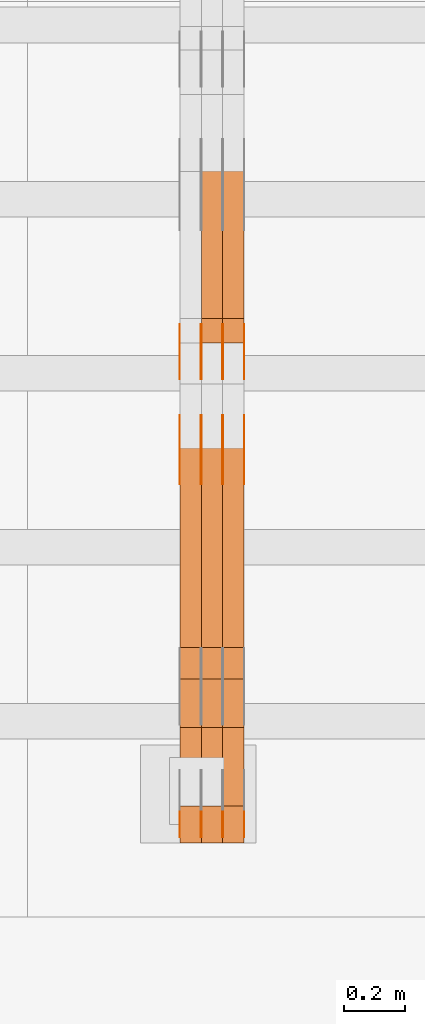
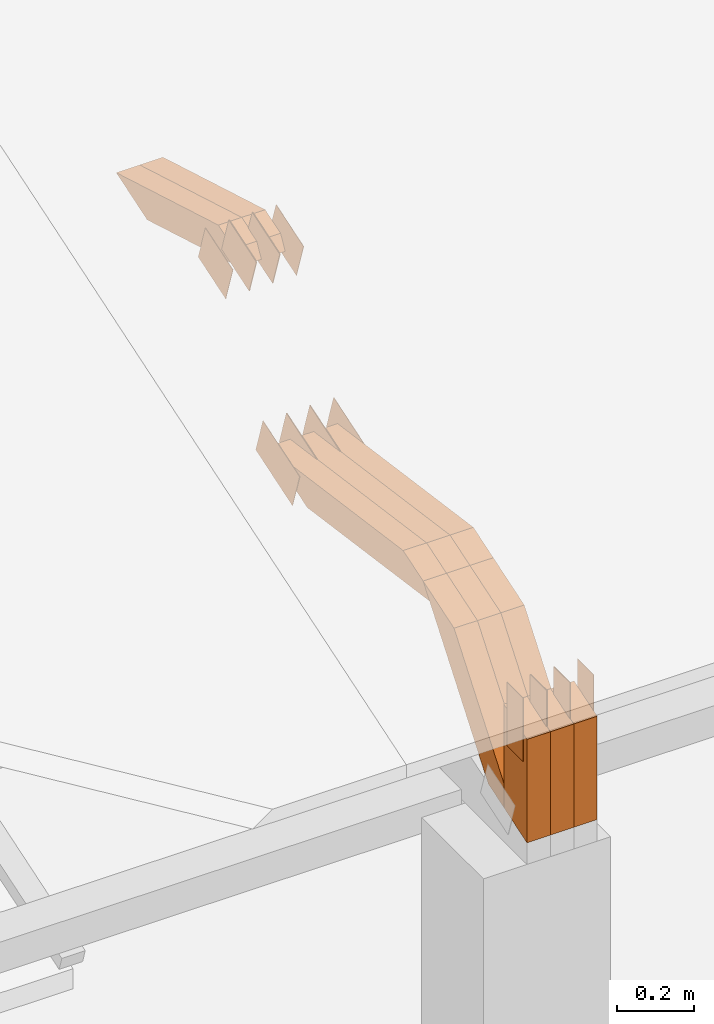
# One storey, part 54 of 385: 29 proxies.
"""IFC2X3 building model written with IfcOpenShell, lengths in millimetres."""

from ifc_helpers import new_model, entity, si_unit, converted_unit, derived_unit, direction, frame, frame_2d, origin, place, context, subcontext, project, spatial, polyline, rectangle, outline, extrude, source, transform, mapped, material, type_object, type_shapes, element, save


model = new_model("IFC2X3")

# Units and contexts
model_context = context("Model", 3, precision=0.01, world=origin(), true_north=direction((6.12303176911189e-17, 1.0)))
body_context = subcontext(model_context, "Body", "Model", "MODEL_VIEW")
ifc_project = project(units=[si_unit("LENGTHUNIT", "METRE", prefix="MILLI"), si_unit("AREAUNIT", "SQUARE_METRE"), si_unit("VOLUMEUNIT", "CUBIC_METRE"), converted_unit("PLANEANGLEUNIT", "DEGREE", entity("IfcRatioMeasure", 0.0174532925199433), si_unit("PLANEANGLEUNIT", "RADIAN"), dimensions=[0, 0, 0, 0, 0, 0, 0]), si_unit("MASSUNIT", "GRAM", prefix="KILO"), derived_unit("MASSDENSITYUNIT", [(si_unit("MASSUNIT", "GRAM", prefix="KILO"), 1), (si_unit("LENGTHUNIT", "METRE"), -3)]), si_unit("TIMEUNIT", "SECOND"), si_unit("FREQUENCYUNIT", "HERTZ"), si_unit("THERMODYNAMICTEMPERATUREUNIT", "DEGREE_CELSIUS"), derived_unit("THERMALTRANSMITTANCEUNIT", [(si_unit("MASSUNIT", "GRAM", prefix="KILO"), 1), (si_unit("THERMODYNAMICTEMPERATUREUNIT", "KELVIN"), -1), (si_unit("TIMEUNIT", "SECOND"), -3)]), derived_unit("VOLUMETRICFLOWRATEUNIT", [(si_unit("LENGTHUNIT", "METRE"), 3), (si_unit("TIMEUNIT", "SECOND"), -1)]), si_unit("ELECTRICCURRENTUNIT", "AMPERE"), si_unit("ELECTRICVOLTAGEUNIT", "VOLT"), si_unit("POWERUNIT", "WATT"), si_unit("FORCEUNIT", "NEWTON", prefix="KILO"), si_unit("ILLUMINANCEUNIT", "LUX"), si_unit("LUMINOUSFLUXUNIT", "LUMEN"), si_unit("LUMINOUSINTENSITYUNIT", "CANDELA"), derived_unit("USERDEFINED", [(si_unit("MASSUNIT", "GRAM", prefix="KILO"), -1), (si_unit("LENGTHUNIT", "METRE"), -2), (si_unit("TIMEUNIT", "SECOND"), 3), (si_unit("LUMINOUSFLUXUNIT", "LUMEN"), 1)]), derived_unit("LINEARVELOCITYUNIT", [(si_unit("LENGTHUNIT", "METRE"), 1), (si_unit("TIMEUNIT", "SECOND"), -1)]), si_unit("PRESSUREUNIT", "PASCAL"), derived_unit("USERDEFINED", [(si_unit("LENGTHUNIT", "METRE"), -2), (si_unit("MASSUNIT", "GRAM", prefix="KILO"), 1), (si_unit("TIMEUNIT", "SECOND"), -2)])], contexts=[model_context])

# Site, building, storey
site_placement = place(None, origin())
site = spatial("IfcSite", under=ifc_project, at=site_placement, CompositionType="ELEMENT")
building_placement = place(site_placement, origin())
building = spatial("IfcBuilding", under=site, at=building_placement, CompositionType="ELEMENT")
storey_placement = place(building_placement, origin())
storey = spatial("IfcBuildingStorey", under=building, at=storey_placement, Name="Default", CompositionType="ELEMENT", Elevation=0.0)

# Proxies
ifc_material_1 = material(Name="IfcSurfaceStyle #133094")
building_element_proxy_type_1 = type_object("IfcBuildingElementProxyType", PredefinedType="NOTDEFINED", material=ifc_material_1)
shared_shape_1 = source(origin(), body_context, "Body", "SweptSolid", [
    extrude(outline(polyline([(-99.9998204243802, -60.000067376167), (99.9998338462265, -60.000067376167), (99.9998204243802, 60.000067376167), (-99.9998338462265, 60.000067376167), (-99.9998204243802, -60.000067376167)])), frame((100.000602015329, 60.0001864986889, 0.0), z_axis=(0.0, 0.0, 1.0), x_axis=(-1.0, 0.0, 0.0)), (0.0, 0.0, 1.0), 1.3),
])
type_shapes(building_element_proxy_type_1, [shared_shape_1])
proxy_1_placement = place(building_placement, frame((9386.29999999998, 4114.85465165112, 513.097031388771), z_axis=(-1.0, 0.0, 0.0), x_axis=(0.0, 0.951056516295124, 0.309016994375039)))
element("IfcBuildingElementProxy", 1, at=proxy_1_placement, inside=storey, type_object=building_element_proxy_type_1, material=ifc_material_1, context=body_context, shape_type="MappedRepresentation", body=[
    mapped(shared_shape_1, transform((0.0, 0.0, 0.0), scale=1.0)),
])
ifc_material_2 = material(Name="IfcSurfaceStyle #133037")
building_element_proxy_type_2 = type_object("IfcBuildingElementProxyType", PredefinedType="NOTDEFINED", material=ifc_material_2)
shared_shape_2 = source(origin(), body_context, "Body", "SweptSolid", [
    extrude(outline(polyline([(-99.9998204243802, -60.000067376167), (99.9998338462265, -60.000067376167), (99.9998204243802, 60.000067376167), (-99.9998338462265, 60.000067376167), (-99.9998204243802, -60.000067376167)])), frame((100.000602015329, 60.0001864986889, 0.0), z_axis=(0.0, 0.0, 1.0), x_axis=(-1.0, 0.0, 0.0)), (0.0, 0.0, 1.0), 1.3),
])
type_shapes(building_element_proxy_type_2, [shared_shape_2])
proxy_2_placement = place(building_placement, frame((9315.0, 4114.85465165112, 513.097031388771), z_axis=(-1.0, 0.0, 0.0), x_axis=(0.0, 0.951056516295124, 0.309016994375039)))
element("IfcBuildingElementProxy", 2, at=proxy_2_placement, inside=storey, type_object=building_element_proxy_type_2, material=ifc_material_2, context=body_context, shape_type="MappedRepresentation", body=[
    mapped(shared_shape_2, transform((0.0, 0.0, 0.0), scale=1.0)),
])
ifc_material_3 = material(Name="IfcSurfaceStyle #132980")
building_element_proxy_type_3 = type_object("IfcBuildingElementProxyType", PredefinedType="NOTDEFINED", material=ifc_material_3)
shared_shape_3 = source(origin(), body_context, "Body", "SweptSolid", [
    extrude(outline(polyline([(-99.9998204243802, -60.000067376167), (99.9998338462265, -60.000067376167), (99.9998204243802, 60.000067376167), (-99.9998338462265, 60.000067376167), (-99.9998204243802, -60.000067376167)])), frame((100.000602015329, 60.0001864986889, 0.0), z_axis=(0.0, 0.0, 1.0), x_axis=(-1.0, 0.0, 0.0)), (0.0, 0.0, 1.0), 1.3),
])
type_shapes(building_element_proxy_type_3, [shared_shape_3])
proxy_3_placement = place(building_placement, frame((9316.29999999998, 4114.85465165112, 513.097031388771), z_axis=(-1.0, 0.0, 0.0), x_axis=(0.0, 0.951056516295124, 0.309016994375039)))
element("IfcBuildingElementProxy", 3, at=proxy_3_placement, inside=storey, type_object=building_element_proxy_type_3, material=ifc_material_3, context=body_context, shape_type="MappedRepresentation", body=[
    mapped(shared_shape_3, transform((0.0, 0.0, 0.0), scale=1.0)),
])
ifc_material_4 = material(Name="IfcSurfaceStyle #132923")
building_element_proxy_type_4 = type_object("IfcBuildingElementProxyType", PredefinedType="NOTDEFINED", material=ifc_material_4)
shared_shape_4 = source(origin(), body_context, "Body", "SweptSolid", [
    extrude(outline(polyline([(-99.9998204243802, -60.000067376167), (99.9998338462265, -60.000067376167), (99.9998204243802, 60.000067376167), (-99.9998338462265, 60.000067376167), (-99.9998204243802, -60.000067376167)])), frame((100.000602015329, 60.0001864986889, 0.0), z_axis=(0.0, 0.0, 1.0), x_axis=(-1.0, 0.0, 0.0)), (0.0, 0.0, 1.0), 1.29999999999998),
])
type_shapes(building_element_proxy_type_4, [shared_shape_4])
proxy_4_placement = place(building_placement, frame((9245.0, 4114.85465165112, 513.097031388771), z_axis=(-1.0, 0.0, 0.0), x_axis=(0.0, 0.951056516295124, 0.309016994375039)))
element("IfcBuildingElementProxy", 4, at=proxy_4_placement, inside=storey, type_object=building_element_proxy_type_4, material=ifc_material_4, context=body_context, shape_type="MappedRepresentation", body=[
    mapped(shared_shape_4, transform((0.0, 0.0, 0.0), scale=1.0)),
])
ifc_material_5 = material(Name="IfcSurfaceStyle #132866")
building_element_proxy_type_5 = type_object("IfcBuildingElementProxyType", PredefinedType="NOTDEFINED", material=ifc_material_5)
shared_shape_5 = source(origin(), body_context, "Body", "SweptSolid", [
    extrude(outline(polyline([(-99.9998204243802, -60.000067376167), (99.9998338462265, -60.000067376167), (99.9998204243802, 60.000067376167), (-99.9998338462265, 60.000067376167), (-99.9998204243802, -60.000067376167)])), frame((100.000602015329, 60.0001864986889, 0.0), z_axis=(0.0, 0.0, 1.0), x_axis=(-1.0, 0.0, 0.0)), (0.0, 0.0, 1.0), 1.29999999999998),
])
type_shapes(building_element_proxy_type_5, [shared_shape_5])
proxy_5_placement = place(building_placement, frame((9246.29999999998, 4114.85465165112, 513.097031388771), z_axis=(-1.0, 0.0, 0.0), x_axis=(0.0, 0.951056516295124, 0.309016994375039)))
element("IfcBuildingElementProxy", 5, at=proxy_5_placement, inside=storey, type_object=building_element_proxy_type_5, material=ifc_material_5, context=body_context, shape_type="MappedRepresentation", body=[
    mapped(shared_shape_5, transform((0.0, 0.0, 0.0), scale=1.0)),
])
ifc_material_6 = material(Name="IfcSurfaceStyle #132809")
building_element_proxy_type_6 = type_object("IfcBuildingElementProxyType", PredefinedType="NOTDEFINED", material=ifc_material_6)
shared_shape_6 = source(origin(), body_context, "Body", "SweptSolid", [
    extrude(outline(polyline([(-99.9998204243802, -60.000067376167), (99.9998338462265, -60.000067376167), (99.9998204243802, 60.000067376167), (-99.9998338462265, 60.000067376167), (-99.9998204243802, -60.000067376167)])), frame((100.000602015329, 60.0001864986889, 0.0), z_axis=(0.0, 0.0, 1.0), x_axis=(-1.0, 0.0, 0.0)), (0.0, 0.0, 1.0), 1.29999999999999),
])
type_shapes(building_element_proxy_type_6, [shared_shape_6])
proxy_6_placement = place(building_placement, frame((9175.0, 4114.85465165112, 513.097031388771), z_axis=(-1.0, 0.0, 0.0), x_axis=(0.0, 0.951056516295124, 0.309016994375039)))
element("IfcBuildingElementProxy", 6, at=proxy_6_placement, inside=storey, type_object=building_element_proxy_type_6, material=ifc_material_6, context=body_context, shape_type="MappedRepresentation", body=[
    mapped(shared_shape_6, transform((0.0, 0.0, 0.0), scale=1.0)),
])
ifc_material_7 = material(Name="IfcSurfaceStyle #125912")
building_element_proxy_type_7 = type_object("IfcBuildingElementProxyType", PredefinedType="NOTDEFINED", material=ifc_material_7)
shared_shape_7 = source(origin(), body_context, "Body", "SweptSolid", [
    extrude(outline(polyline([(-74.999865998172, -60.0000306612919), (74.999869989555, -60.0000306612919), (74.999865998172, 60.0000306612919), (-74.999869989555, 60.0000306612919), (-74.999865998172, -60.0000306612919)])), frame((75.0006726017528, 60.0001996460842, 0.0), z_axis=(0.0, 0.0, 1.0), x_axis=(-1.0, 0.0, 0.0)), (0.0, 0.0, 1.0), 1.3),
])
type_shapes(building_element_proxy_type_7, [shared_shape_7])
proxy_7_placement = place(building_placement, frame((9386.29999999998, 4460.38978242656, 957.314497110567), z_axis=(-1.0, 0.0, 0.0), x_axis=(0.0, 0.951056516295154, 0.309016994374948)))
element("IfcBuildingElementProxy", 7, at=proxy_7_placement, inside=storey, type_object=building_element_proxy_type_7, material=ifc_material_7, context=body_context, shape_type="MappedRepresentation", body=[
    mapped(shared_shape_7, transform((0.0, 0.0, 0.0), scale=1.0)),
])
ifc_material_8 = material(Name="IfcSurfaceStyle #125855")
building_element_proxy_type_8 = type_object("IfcBuildingElementProxyType", PredefinedType="NOTDEFINED", material=ifc_material_8)
shared_shape_8 = source(origin(), body_context, "Body", "SweptSolid", [
    extrude(outline(polyline([(-74.999865998172, -60.0000306612919), (74.999869989555, -60.0000306612919), (74.999865998172, 60.0000306612919), (-74.999869989555, 60.0000306612919), (-74.999865998172, -60.0000306612919)])), frame((75.0006726017528, 60.0001996460842, 0.0), z_axis=(0.0, 0.0, 1.0), x_axis=(-1.0, 0.0, 0.0)), (0.0, 0.0, 1.0), 1.3),
])
type_shapes(building_element_proxy_type_8, [shared_shape_8])
proxy_8_placement = place(building_placement, frame((9315.0, 4460.38978242656, 957.314497110567), z_axis=(-1.0, 0.0, 0.0), x_axis=(0.0, 0.951056516295154, 0.309016994374948)))
element("IfcBuildingElementProxy", 8, at=proxy_8_placement, inside=storey, type_object=building_element_proxy_type_8, material=ifc_material_8, context=body_context, shape_type="MappedRepresentation", body=[
    mapped(shared_shape_8, transform((0.0, 0.0, 0.0), scale=1.0)),
])
ifc_material_9 = material(Name="IfcSurfaceStyle #125798")
building_element_proxy_type_9 = type_object("IfcBuildingElementProxyType", PredefinedType="NOTDEFINED", material=ifc_material_9)
shared_shape_9 = source(origin(), body_context, "Body", "SweptSolid", [
    extrude(outline(polyline([(-74.999865998172, -60.0000306612919), (74.999869989555, -60.0000306612919), (74.999865998172, 60.0000306612919), (-74.999869989555, 60.0000306612919), (-74.999865998172, -60.0000306612919)])), frame((75.0006726017528, 60.0001996460842, 0.0), z_axis=(0.0, 0.0, 1.0), x_axis=(-1.0, 0.0, 0.0)), (0.0, 0.0, 1.0), 1.3),
])
type_shapes(building_element_proxy_type_9, [shared_shape_9])
proxy_9_placement = place(building_placement, frame((9316.29999999998, 4460.38978242656, 957.314497110567), z_axis=(-1.0, 0.0, 0.0), x_axis=(0.0, 0.951056516295154, 0.309016994374948)))
element("IfcBuildingElementProxy", 9, at=proxy_9_placement, inside=storey, type_object=building_element_proxy_type_9, material=ifc_material_9, context=body_context, shape_type="MappedRepresentation", body=[
    mapped(shared_shape_9, transform((0.0, 0.0, 0.0), scale=1.0)),
])
ifc_material_10 = material(Name="IfcSurfaceStyle #125741")
building_element_proxy_type_10 = type_object("IfcBuildingElementProxyType", PredefinedType="NOTDEFINED", material=ifc_material_10)
shared_shape_10 = source(origin(), body_context, "Body", "SweptSolid", [
    extrude(outline(polyline([(-74.999865998172, -60.0000306612919), (74.999869989555, -60.0000306612919), (74.999865998172, 60.0000306612919), (-74.999869989555, 60.0000306612919), (-74.999865998172, -60.0000306612919)])), frame((75.0006726017528, 60.0001996460842, 0.0), z_axis=(0.0, 0.0, 1.0), x_axis=(-1.0, 0.0, 0.0)), (0.0, 0.0, 1.0), 1.29999999999999),
])
type_shapes(building_element_proxy_type_10, [shared_shape_10])
proxy_10_placement = place(building_placement, frame((9245.0, 4460.38978242656, 957.314497110567), z_axis=(-1.0, 0.0, 0.0), x_axis=(0.0, 0.951056516295154, 0.309016994374948)))
element("IfcBuildingElementProxy", 10, at=proxy_10_placement, inside=storey, type_object=building_element_proxy_type_10, material=ifc_material_10, context=body_context, shape_type="MappedRepresentation", body=[
    mapped(shared_shape_10, transform((0.0, 0.0, 0.0), scale=1.0)),
])
ifc_material_11 = material(Name="IfcSurfaceStyle #125684")
building_element_proxy_type_11 = type_object("IfcBuildingElementProxyType", PredefinedType="NOTDEFINED", material=ifc_material_11)
shared_shape_11 = source(origin(), body_context, "Body", "SweptSolid", [
    extrude(outline(polyline([(-74.999865998172, -60.0000306612919), (74.999869989555, -60.0000306612919), (74.999865998172, 60.0000306612919), (-74.999869989555, 60.0000306612919), (-74.999865998172, -60.0000306612919)])), frame((75.0006726017528, 60.0001996460842, 0.0), z_axis=(0.0, 0.0, 1.0), x_axis=(-1.0, 0.0, 0.0)), (0.0, 0.0, 1.0), 1.29999999999999),
])
type_shapes(building_element_proxy_type_11, [shared_shape_11])
proxy_11_placement = place(building_placement, frame((9246.29999999998, 4460.38978242656, 957.314497110567), z_axis=(-1.0, 0.0, 0.0), x_axis=(0.0, 0.951056516295154, 0.309016994374948)))
element("IfcBuildingElementProxy", 11, at=proxy_11_placement, inside=storey, type_object=building_element_proxy_type_11, material=ifc_material_11, context=body_context, shape_type="MappedRepresentation", body=[
    mapped(shared_shape_11, transform((0.0, 0.0, 0.0), scale=1.0)),
])
ifc_material_12 = material(Name="IfcSurfaceStyle #125627")
building_element_proxy_type_12 = type_object("IfcBuildingElementProxyType", PredefinedType="NOTDEFINED", material=ifc_material_12)
shared_shape_12 = source(origin(), body_context, "Body", "SweptSolid", [
    extrude(outline(polyline([(-74.999865998172, -60.0000306612919), (74.999869989555, -60.0000306612919), (74.999865998172, 60.0000306612919), (-74.999869989555, 60.0000306612919), (-74.999865998172, -60.0000306612919)])), frame((75.0006726017528, 60.0001996460842, 0.0), z_axis=(0.0, 0.0, 1.0), x_axis=(-1.0, 0.0, 0.0)), (0.0, 0.0, 1.0), 1.29999999999999),
])
type_shapes(building_element_proxy_type_12, [shared_shape_12])
proxy_12_placement = place(building_placement, frame((9175.0, 4460.38978242656, 957.314497110567), z_axis=(-1.0, 0.0, 0.0), x_axis=(0.0, 0.951056516295154, 0.309016994374948)))
element("IfcBuildingElementProxy", 12, at=proxy_12_placement, inside=storey, type_object=building_element_proxy_type_12, material=ifc_material_12, context=body_context, shape_type="MappedRepresentation", body=[
    mapped(shared_shape_12, transform((0.0, 0.0, 0.0), scale=1.0)),
])
ifc_material_13 = material(Name="IfcSurfaceStyle #123860")
building_element_proxy_type_13 = type_object("IfcBuildingElementProxyType", PredefinedType="NOTDEFINED", material=ifc_material_13)
shared_shape_13 = source(origin(), body_context, "Body", "SweptSolid", [
    extrude(rectangle(XDim=199.999969482422, YDim=84.0, at=frame_2d((1.4210854715202e-14, 0.0), x_axis=(1.0, 0.0))), frame((100.000010815955, 42.0, 0.0), z_axis=(0.0, 0.0, 1.0), x_axis=(-1.0, 0.0, 0.0)), (0.0, 0.0, 1.0), 1.3),
])
type_shapes(building_element_proxy_type_13, [shared_shape_13])
proxy_13_placement = place(building_placement, frame((9386.29999999998, 3042.0, 514.460048047401), z_axis=(-1.0, 0.0, 0.0), x_axis=(0.0, 0.0, -1.0)))
element("IfcBuildingElementProxy", 13, at=proxy_13_placement, inside=storey, type_object=building_element_proxy_type_13, material=ifc_material_13, context=body_context, shape_type="MappedRepresentation", body=[
    mapped(shared_shape_13, transform((0.0, 0.0, 0.0), scale=1.0)),
])
ifc_material_14 = material(Name="IfcSurfaceStyle #123803")
building_element_proxy_type_14 = type_object("IfcBuildingElementProxyType", PredefinedType="NOTDEFINED", material=ifc_material_14)
shared_shape_14 = source(origin(), body_context, "Body", "SweptSolid", [
    extrude(rectangle(XDim=199.999969482422, YDim=84.0, at=frame_2d((1.4210854715202e-14, 0.0), x_axis=(1.0, 0.0))), frame((100.000010815955, 42.0, 0.0), z_axis=(0.0, 0.0, 1.0), x_axis=(-1.0, 0.0, 0.0)), (0.0, 0.0, 1.0), 1.3),
])
type_shapes(building_element_proxy_type_14, [shared_shape_14])
proxy_14_placement = place(building_placement, frame((9315.0, 3042.0, 514.460048047401), z_axis=(-1.0, 0.0, 0.0), x_axis=(0.0, 0.0, -1.0)))
element("IfcBuildingElementProxy", 14, at=proxy_14_placement, inside=storey, type_object=building_element_proxy_type_14, material=ifc_material_14, context=body_context, shape_type="MappedRepresentation", body=[
    mapped(shared_shape_14, transform((0.0, 0.0, 0.0), scale=1.0)),
])
ifc_material_15 = material(Name="IfcSurfaceStyle #123746")
building_element_proxy_type_15 = type_object("IfcBuildingElementProxyType", PredefinedType="NOTDEFINED", material=ifc_material_15)
shared_shape_15 = source(origin(), body_context, "Body", "SweptSolid", [
    extrude(rectangle(XDim=199.999969482422, YDim=84.0, at=frame_2d((1.4210854715202e-14, 0.0), x_axis=(1.0, 0.0))), frame((100.000010815955, 42.0, 0.0), z_axis=(0.0, 0.0, 1.0), x_axis=(-1.0, 0.0, 0.0)), (0.0, 0.0, 1.0), 1.3),
])
type_shapes(building_element_proxy_type_15, [shared_shape_15])
proxy_15_placement = place(building_placement, frame((9316.29999999998, 3042.0, 514.460048047401), z_axis=(-1.0, 0.0, 0.0), x_axis=(0.0, 0.0, -1.0)))
element("IfcBuildingElementProxy", 15, at=proxy_15_placement, inside=storey, type_object=building_element_proxy_type_15, material=ifc_material_15, context=body_context, shape_type="MappedRepresentation", body=[
    mapped(shared_shape_15, transform((0.0, 0.0, 0.0), scale=1.0)),
])
ifc_material_16 = material(Name="IfcSurfaceStyle #123689")
building_element_proxy_type_16 = type_object("IfcBuildingElementProxyType", PredefinedType="NOTDEFINED", material=ifc_material_16)
shared_shape_16 = source(origin(), body_context, "Body", "SweptSolid", [
    extrude(rectangle(XDim=199.999969482422, YDim=84.0, at=frame_2d((1.4210854715202e-14, 0.0), x_axis=(1.0, 0.0))), frame((100.000010815955, 42.0, 0.0), z_axis=(0.0, 0.0, 1.0), x_axis=(-1.0, 0.0, 0.0)), (0.0, 0.0, 1.0), 1.29999999999998),
])
type_shapes(building_element_proxy_type_16, [shared_shape_16])
proxy_16_placement = place(building_placement, frame((9245.0, 3042.0, 514.460048047401), z_axis=(-1.0, 0.0, 0.0), x_axis=(0.0, 0.0, -1.0)))
element("IfcBuildingElementProxy", 16, at=proxy_16_placement, inside=storey, type_object=building_element_proxy_type_16, material=ifc_material_16, context=body_context, shape_type="MappedRepresentation", body=[
    mapped(shared_shape_16, transform((0.0, 0.0, 0.0), scale=1.0)),
])
ifc_material_17 = material(Name="IfcSurfaceStyle #123632")
building_element_proxy_type_17 = type_object("IfcBuildingElementProxyType", PredefinedType="NOTDEFINED", material=ifc_material_17)
shared_shape_17 = source(origin(), body_context, "Body", "SweptSolid", [
    extrude(rectangle(XDim=199.999969482422, YDim=84.0, at=frame_2d((1.4210854715202e-14, 0.0), x_axis=(1.0, 0.0))), frame((100.000010815955, 42.0, 0.0), z_axis=(0.0, 0.0, 1.0), x_axis=(-1.0, 0.0, 0.0)), (0.0, 0.0, 1.0), 1.29999999999998),
])
type_shapes(building_element_proxy_type_17, [shared_shape_17])
proxy_17_placement = place(building_placement, frame((9246.29999999998, 3042.0, 514.460048047401), z_axis=(-1.0, 0.0, 0.0), x_axis=(0.0, 0.0, -1.0)))
element("IfcBuildingElementProxy", 17, at=proxy_17_placement, inside=storey, type_object=building_element_proxy_type_17, material=ifc_material_17, context=body_context, shape_type="MappedRepresentation", body=[
    mapped(shared_shape_17, transform((0.0, 0.0, 0.0), scale=1.0)),
])
ifc_material_18 = material(Name="IfcSurfaceStyle #123575")
building_element_proxy_type_18 = type_object("IfcBuildingElementProxyType", PredefinedType="NOTDEFINED", material=ifc_material_18)
shared_shape_18 = source(origin(), body_context, "Body", "SweptSolid", [
    extrude(rectangle(XDim=199.999969482422, YDim=84.0, at=frame_2d((1.4210854715202e-14, 0.0), x_axis=(1.0, 0.0))), frame((100.000010815955, 42.0, 0.0), z_axis=(0.0, 0.0, 1.0), x_axis=(-1.0, 0.0, 0.0)), (0.0, 0.0, 1.0), 1.29999999999999),
])
type_shapes(building_element_proxy_type_18, [shared_shape_18])
proxy_18_placement = place(building_placement, frame((9175.0, 3042.0, 514.460048047401), z_axis=(-1.0, 0.0, 0.0), x_axis=(0.0, 0.0, -1.0)))
element("IfcBuildingElementProxy", 18, at=proxy_18_placement, inside=storey, type_object=building_element_proxy_type_18, material=ifc_material_18, context=body_context, shape_type="MappedRepresentation", body=[
    mapped(shared_shape_18, transform((0.0, 0.0, 0.0), scale=1.0)),
])
ifc_material_19 = material(Name="IfcSurfaceStyle #113384")
building_element_proxy_type_19 = type_object("IfcBuildingElementProxyType", Name="T1-W12 113382", PredefinedType="NOTDEFINED", material=ifc_material_19)
shared_shape_19 = source(origin(), body_context, "Body", "SweptSolid", [
    extrude(outline(polyline([(-249.405625983165, -47.5001691155616), (243.345753908996, -47.5001691155616), (232.115534842595, 2.39993474701938e-05), (162.527010966644, 47.5001571158879), (-388.58267373507, 47.5001571158879), (-249.405625983165, -47.5001691155616)])), frame((243.345867653852, 47.5001571158879, 0.0), z_axis=(0.0, 0.0, 1.0), x_axis=(-1.0, 0.0, 0.0)), (0.0, 0.0, 1.0), 70.0),
])
type_shapes(building_element_proxy_type_19, [shared_shape_19])
proxy_19_placement = place(building_placement, frame((9385.0, 4581.32698473632, 976.172276753357), z_axis=(-1.0, 0.0, 0.0), x_axis=(0.0, 0.959722067881787, -0.280951156645966)))
element("IfcBuildingElementProxy", 19, at=proxy_19_placement, inside=storey, type_object=building_element_proxy_type_19, material=ifc_material_19, Name="T1-W12", context=body_context, shape_type="MappedRepresentation", body=[
    mapped(shared_shape_19, transform((0.0, 0.0, 0.0), scale=1.0)),
])
ifc_material_20 = material(Name="IfcSurfaceStyle #113318")
building_element_proxy_type_20 = type_object("IfcBuildingElementProxyType", Name="T1-W12 113316", PredefinedType="NOTDEFINED", material=ifc_material_20)
shared_shape_20 = source(origin(), body_context, "Body", "SweptSolid", [
    extrude(outline(polyline([(-249.405625983165, -47.5001691155616), (243.345753908996, -47.5001691155616), (232.115534842595, 2.39993474701938e-05), (162.527010966644, 47.5001571158879), (-388.58267373507, 47.5001571158879), (-249.405625983165, -47.5001691155616)])), frame((243.345867653852, 47.5001571158879, 0.0), z_axis=(0.0, 0.0, 1.0), x_axis=(-1.0, 0.0, 0.0)), (0.0, 0.0, 1.0), 70.0),
])
type_shapes(building_element_proxy_type_20, [shared_shape_20])
proxy_20_placement = place(building_placement, frame((9315.0, 4581.32698473632, 976.172276753357), z_axis=(-1.0, 0.0, 0.0), x_axis=(0.0, 0.959722067881787, -0.280951156645966)))
element("IfcBuildingElementProxy", 20, at=proxy_20_placement, inside=storey, type_object=building_element_proxy_type_20, material=ifc_material_20, Name="T1-W12", context=body_context, shape_type="MappedRepresentation", body=[
    mapped(shared_shape_20, transform((0.0, 0.0, 0.0), scale=1.0)),
])
ifc_material_21 = material(Name="IfcSurfaceStyle #112592")
building_element_proxy_type_21 = type_object("IfcBuildingElementProxyType", Name="T1-W3 112590", PredefinedType="NOTDEFINED", material=ifc_material_21)
shared_shape_21 = source(origin(), body_context, "Body", "SweptSolid", [
    extrude(outline(polyline([(-314.232579911788, -47.5000200125938), (325.164873061766, -47.5000200125938), (297.999869081008, 6.48085173424295e-05), (200.434027234171, 47.4999876083351), (-509.366189465157, 47.4999876083352), (-314.232579911788, -47.5000200125938)])), frame((325.164873061766, 47.5001564752191, 0.0), z_axis=(0.0, 0.0, 1.0), x_axis=(-1.0, 0.0, 0.0)), (0.0, 0.0, 1.0), 70.0),
])
type_shapes(building_element_proxy_type_21, [shared_shape_21])
proxy_21_placement = place(building_placement, frame((9385.0, 3457.43747924876, 620.49890325051), z_axis=(-1.0, 0.0, 0.0), x_axis=(0.0, 0.990367219823621, -0.138465771578512)))
element("IfcBuildingElementProxy", 21, at=proxy_21_placement, inside=storey, type_object=building_element_proxy_type_21, material=ifc_material_21, Name="T1-W3", context=body_context, shape_type="MappedRepresentation", body=[
    mapped(shared_shape_21, transform((0.0, 0.0, 0.0), scale=1.0)),
])
ifc_material_22 = material(Name="IfcSurfaceStyle #112526")
building_element_proxy_type_22 = type_object("IfcBuildingElementProxyType", Name="T1-W3 112524", PredefinedType="NOTDEFINED", material=ifc_material_22)
shared_shape_22 = source(origin(), body_context, "Body", "SweptSolid", [
    extrude(outline(polyline([(-314.232579911788, -47.5000200125938), (325.164873061766, -47.5000200125938), (297.999869081008, 6.48085173424295e-05), (200.434027234171, 47.4999876083351), (-509.366189465157, 47.4999876083352), (-314.232579911788, -47.5000200125938)])), frame((325.164873061766, 47.5001564752191, 0.0), z_axis=(0.0, 0.0, 1.0), x_axis=(-1.0, 0.0, 0.0)), (0.0, 0.0, 1.0), 70.0),
])
type_shapes(building_element_proxy_type_22, [shared_shape_22])
proxy_22_placement = place(building_placement, frame((9315.0, 3457.43747924876, 620.49890325051), z_axis=(-1.0, 0.0, 0.0), x_axis=(0.0, 0.990367219823621, -0.138465771578512)))
element("IfcBuildingElementProxy", 22, at=proxy_22_placement, inside=storey, type_object=building_element_proxy_type_22, material=ifc_material_22, Name="T1-W3", context=body_context, shape_type="MappedRepresentation", body=[
    mapped(shared_shape_22, transform((0.0, 0.0, 0.0), scale=1.0)),
])
ifc_material_23 = material(Name="IfcSurfaceStyle #112460")
building_element_proxy_type_23 = type_object("IfcBuildingElementProxyType", Name="T1-W3 112458", PredefinedType="NOTDEFINED", material=ifc_material_23)
shared_shape_23 = source(origin(), body_context, "Body", "SweptSolid", [
    extrude(outline(polyline([(-314.232579911788, -47.5000200125938), (325.164873061766, -47.5000200125938), (297.999869081008, 6.48085173424295e-05), (200.434027234171, 47.4999876083351), (-509.366189465157, 47.4999876083352), (-314.232579911788, -47.5000200125938)])), frame((325.164873061766, 47.5001564752191, 0.0), z_axis=(0.0, 0.0, 1.0), x_axis=(-1.0, 0.0, 0.0)), (0.0, 0.0, 1.0), 70.0),
])
type_shapes(building_element_proxy_type_23, [shared_shape_23])
proxy_23_placement = place(building_placement, frame((9245.0, 3457.43747924876, 620.49890325051), z_axis=(-1.0, 0.0, 0.0), x_axis=(0.0, 0.990367219823621, -0.138465771578512)))
element("IfcBuildingElementProxy", 23, at=proxy_23_placement, inside=storey, type_object=building_element_proxy_type_23, material=ifc_material_23, Name="T1-W3", context=body_context, shape_type="MappedRepresentation", body=[
    mapped(shared_shape_23, transform((0.0, 0.0, 0.0), scale=1.0)),
])
ifc_material_24 = material(Name="IfcSurfaceStyle #112196")
building_element_proxy_type_24 = type_object("IfcBuildingElementProxyType", Name="T1-W14 112194", PredefinedType="NOTDEFINED", material=ifc_material_24)
shared_shape_24 = source(origin(), body_context, "Body", "SweptSolid", [
    extrude(outline(polyline([(-374.484689776928, -47.499919737532), (177.199556189275, -47.499919737532), (246.893257937645, -5.36774925340877e-05), (185.487930694801, 47.4999465762783), (-235.096055044793, 47.4999465762784), (-374.484689776928, -47.499919737532)])), frame((246.893257937645, 47.5000959779252, 0.0), z_axis=(0.0, 0.0, 1.0), x_axis=(-1.0, 0.0, 0.0)), (0.0, 0.0, 1.0), 70.0),
])
type_shapes(building_element_proxy_type_24, [shared_shape_24])
proxy_24_placement = place(building_placement, frame((9385.0, 3022.42877773025, 136.329406512195), z_axis=(-1.0, 0.0, 0.0), x_axis=(0.0, 0.611854146609475, 0.790970608352037)))
element("IfcBuildingElementProxy", 24, at=proxy_24_placement, inside=storey, type_object=building_element_proxy_type_24, material=ifc_material_24, Name="T1-W14", context=body_context, shape_type="MappedRepresentation", body=[
    mapped(shared_shape_24, transform((0.0, 0.0, 0.0), scale=1.0)),
])
ifc_material_25 = material(Name="IfcSurfaceStyle #112130")
building_element_proxy_type_25 = type_object("IfcBuildingElementProxyType", Name="T1-W14 112128", PredefinedType="NOTDEFINED", material=ifc_material_25)
shared_shape_25 = source(origin(), body_context, "Body", "SweptSolid", [
    extrude(outline(polyline([(-374.484689776928, -47.499919737532), (177.199556189275, -47.499919737532), (246.893257937645, -5.36774925340877e-05), (185.487930694801, 47.4999465762783), (-235.096055044793, 47.4999465762784), (-374.484689776928, -47.499919737532)])), frame((246.893257937645, 47.5000959779252, 0.0), z_axis=(0.0, 0.0, 1.0), x_axis=(-1.0, 0.0, 0.0)), (0.0, 0.0, 1.0), 70.0),
])
type_shapes(building_element_proxy_type_25, [shared_shape_25])
proxy_25_placement = place(building_placement, frame((9315.0, 3022.42877773025, 136.329406512195), z_axis=(-1.0, 0.0, 0.0), x_axis=(0.0, 0.611854146609475, 0.790970608352037)))
element("IfcBuildingElementProxy", 25, at=proxy_25_placement, inside=storey, type_object=building_element_proxy_type_25, material=ifc_material_25, Name="T1-W14", context=body_context, shape_type="MappedRepresentation", body=[
    mapped(shared_shape_25, transform((0.0, 0.0, 0.0), scale=1.0)),
])
ifc_material_26 = material(Name="IfcSurfaceStyle #112064")
building_element_proxy_type_26 = type_object("IfcBuildingElementProxyType", Name="T1-W14 112062", PredefinedType="NOTDEFINED", material=ifc_material_26)
shared_shape_26 = source(origin(), body_context, "Body", "SweptSolid", [
    extrude(outline(polyline([(-374.484689776928, -47.499919737532), (177.199556189275, -47.499919737532), (246.893257937645, -5.36774925340877e-05), (185.487930694801, 47.4999465762783), (-235.096055044793, 47.4999465762784), (-374.484689776928, -47.499919737532)])), frame((246.893257937645, 47.5000959779252, 0.0), z_axis=(0.0, 0.0, 1.0), x_axis=(-1.0, 0.0, 0.0)), (0.0, 0.0, 1.0), 70.0),
])
type_shapes(building_element_proxy_type_26, [shared_shape_26])
proxy_26_placement = place(building_placement, frame((9245.0, 3022.42877773025, 136.329406512195), z_axis=(-1.0, 0.0, 0.0), x_axis=(0.0, 0.611854146609475, 0.790970608352037)))
element("IfcBuildingElementProxy", 26, at=proxy_26_placement, inside=storey, type_object=building_element_proxy_type_26, material=ifc_material_26, Name="T1-W14", context=body_context, shape_type="MappedRepresentation", body=[
    mapped(shared_shape_26, transform((0.0, 0.0, 0.0), scale=1.0)),
])
ifc_material_27 = material(Name="IfcSurfaceStyle #111998")
building_element_proxy_type_27 = type_object("IfcBuildingElementProxyType", Name="T1-E3 111996", PredefinedType="NOTDEFINED", material=ifc_material_27)
shared_shape_27 = source(origin(), body_context, "Body", "SweptSolid", [
    extrude(outline(polyline([(-182.839673995971, -60.0), (143.849313735962, -60.0), (182.839677810669, 60.0), (-143.84931755066, 60.0), (-182.839673995971, -60.0)])), frame((182.839677810669, 60.0, 0.0), z_axis=(0.0, 0.0, 1.0), x_axis=(-1.0, 0.0, 0.0)), (0.0, 0.0, 1.0), 70.0),
])
type_shapes(building_element_proxy_type_27, [shared_shape_27])
proxy_27_placement = place(building_placement, frame((9385.0, 2940.0, 68.27587890625), z_axis=(-1.0, 0.0, 0.0), x_axis=(0.0, 0.0, 1.0)))
element("IfcBuildingElementProxy", 27, at=proxy_27_placement, inside=storey, type_object=building_element_proxy_type_27, material=ifc_material_27, Name="T1-E3", context=body_context, shape_type="MappedRepresentation", body=[
    mapped(shared_shape_27, transform((0.0, 0.0, 0.0), scale=1.0)),
])
ifc_material_28 = material(Name="IfcSurfaceStyle #111941")
building_element_proxy_type_28 = type_object("IfcBuildingElementProxyType", Name="T1-E3 111939", PredefinedType="NOTDEFINED", material=ifc_material_28)
shared_shape_28 = source(origin(), body_context, "Body", "SweptSolid", [
    extrude(outline(polyline([(-182.839673995971, -60.0), (143.849313735962, -60.0), (182.839677810669, 60.0), (-143.84931755066, 60.0), (-182.839673995971, -60.0)])), frame((182.839677810669, 60.0, 0.0), z_axis=(0.0, 0.0, 1.0), x_axis=(-1.0, 0.0, 0.0)), (0.0, 0.0, 1.0), 70.0),
])
type_shapes(building_element_proxy_type_28, [shared_shape_28])
proxy_28_placement = place(building_placement, frame((9315.0, 2940.0, 68.27587890625), z_axis=(-1.0, 0.0, 0.0), x_axis=(0.0, 0.0, 1.0)))
element("IfcBuildingElementProxy", 28, at=proxy_28_placement, inside=storey, type_object=building_element_proxy_type_28, material=ifc_material_28, Name="T1-E3", context=body_context, shape_type="MappedRepresentation", body=[
    mapped(shared_shape_28, transform((0.0, 0.0, 0.0), scale=1.0)),
])
ifc_material_29 = material(Name="IfcSurfaceStyle #111884")
building_element_proxy_type_29 = type_object("IfcBuildingElementProxyType", Name="T1-E3 111882", PredefinedType="NOTDEFINED", material=ifc_material_29)
shared_shape_29 = source(origin(), body_context, "Body", "SweptSolid", [
    extrude(outline(polyline([(-182.839673995971, -60.0), (143.849313735962, -60.0), (182.839677810669, 60.0), (-143.84931755066, 60.0), (-182.839673995971, -60.0)])), frame((182.839677810669, 60.0, 0.0), z_axis=(0.0, 0.0, 1.0), x_axis=(-1.0, 0.0, 0.0)), (0.0, 0.0, 1.0), 70.0),
])
type_shapes(building_element_proxy_type_29, [shared_shape_29])
proxy_29_placement = place(building_placement, frame((9245.0, 2940.0, 68.27587890625), z_axis=(-1.0, 0.0, 0.0), x_axis=(0.0, 0.0, 1.0)))
element("IfcBuildingElementProxy", 29, at=proxy_29_placement, inside=storey, type_object=building_element_proxy_type_29, material=ifc_material_29, Name="T1-E3", context=body_context, shape_type="MappedRepresentation", body=[
    mapped(shared_shape_29, transform((0.0, 0.0, 0.0), scale=1.0)),
])

save(model, "model.ifc")
